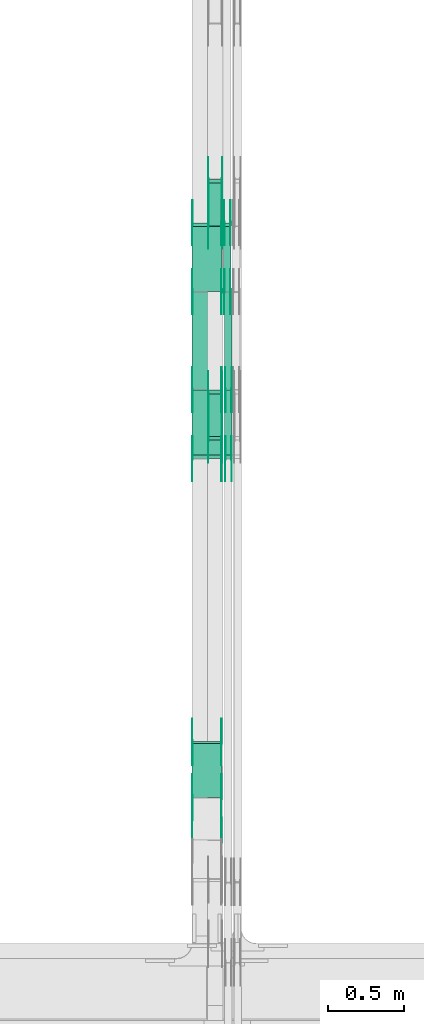
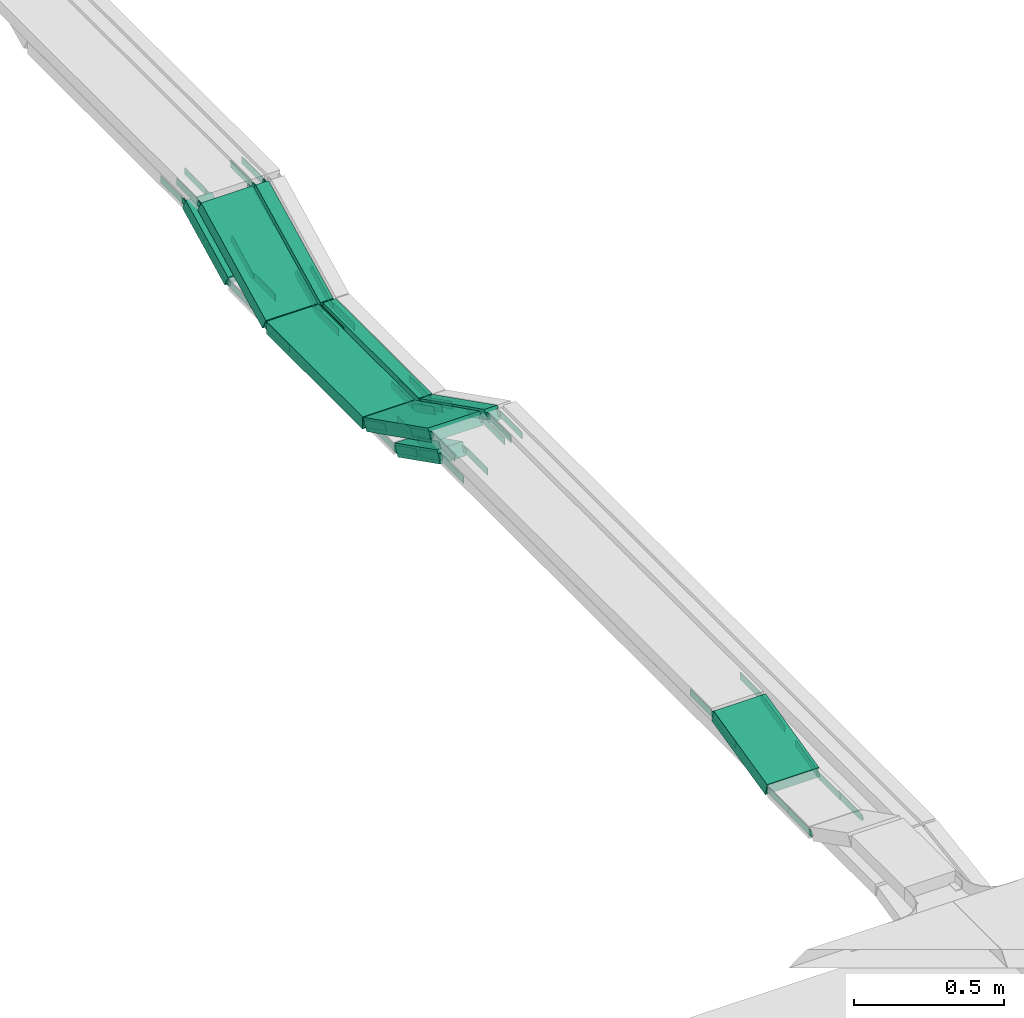
# One storey, part 18 of 27: 57 flow fittings, 9 flow segments.
"""IFC2X3 building model written with IfcOpenShell, lengths in millimetres."""

from ifc_helpers import new_model, entity, si_unit, converted_unit, derived_unit, direction, frame, frame_2d, origin, origin_2d_with_axis, place, context, subcontext, project, spatial, polyline, circle_curve, parameter, trimmed, segment, composite_curve, rectangle, outline, extrude, source, transform, mapped, material, type_object, type_shapes, element, save


model = new_model("IFC2X3")

# Units and contexts
model_context = context("Model", 3, precision=0.01, world=origin(), true_north=direction((6.12303176911189e-17, 1.0)))
body_context = subcontext(model_context, "Body", "Model", "MODEL_VIEW")
ifc_project = project(units=[si_unit("LENGTHUNIT", "METRE", prefix="MILLI"), si_unit("AREAUNIT", "SQUARE_METRE"), si_unit("VOLUMEUNIT", "CUBIC_METRE"), converted_unit("PLANEANGLEUNIT", "DEGREE", entity("IfcRatioMeasure", 0.0174532925199433), si_unit("PLANEANGLEUNIT", "RADIAN"), dimensions=[0, 0, 0, 0, 0, 0, 0]), si_unit("MASSUNIT", "GRAM", prefix="KILO"), derived_unit("MASSDENSITYUNIT", [(si_unit("MASSUNIT", "GRAM", prefix="KILO"), 1), (si_unit("LENGTHUNIT", "METRE"), -3)]), derived_unit("MOMENTOFINERTIAUNIT", [(si_unit("LENGTHUNIT", "METRE"), 4)]), si_unit("TIMEUNIT", "SECOND"), si_unit("FREQUENCYUNIT", "HERTZ"), si_unit("THERMODYNAMICTEMPERATUREUNIT", "DEGREE_CELSIUS"), derived_unit("THERMALTRANSMITTANCEUNIT", [(si_unit("MASSUNIT", "GRAM", prefix="KILO"), 1), (si_unit("THERMODYNAMICTEMPERATUREUNIT", "KELVIN"), -1), (si_unit("TIMEUNIT", "SECOND"), -3)]), derived_unit("VOLUMETRICFLOWRATEUNIT", [(si_unit("LENGTHUNIT", "METRE"), 3), (si_unit("TIMEUNIT", "SECOND"), -1)]), derived_unit("MASSFLOWRATEUNIT", [(si_unit("MASSUNIT", "GRAM", prefix="KILO"), 1), (si_unit("TIMEUNIT", "SECOND"), -1)]), derived_unit("ROTATIONALFREQUENCYUNIT", [(si_unit("TIMEUNIT", "SECOND"), -1)]), si_unit("ELECTRICCURRENTUNIT", "AMPERE"), si_unit("ELECTRICVOLTAGEUNIT", "VOLT"), si_unit("POWERUNIT", "WATT"), si_unit("FORCEUNIT", "NEWTON", prefix="KILO"), si_unit("ILLUMINANCEUNIT", "LUX"), si_unit("LUMINOUSFLUXUNIT", "LUMEN"), si_unit("LUMINOUSINTENSITYUNIT", "CANDELA"), derived_unit("USERDEFINED", [(si_unit("MASSUNIT", "GRAM", prefix="KILO"), -1), (si_unit("LENGTHUNIT", "METRE"), -2), (si_unit("TIMEUNIT", "SECOND"), 3), (si_unit("LUMINOUSFLUXUNIT", "LUMEN"), 1)]), derived_unit("LINEARVELOCITYUNIT", [(si_unit("LENGTHUNIT", "METRE"), 1), (si_unit("TIMEUNIT", "SECOND"), -1)]), si_unit("PRESSUREUNIT", "PASCAL"), derived_unit("USERDEFINED", [(si_unit("LENGTHUNIT", "METRE"), -2), (si_unit("MASSUNIT", "GRAM", prefix="KILO"), 1), (si_unit("TIMEUNIT", "SECOND"), -2)]), derived_unit("LINEARFORCEUNIT", [(si_unit("MASSUNIT", "GRAM", prefix="KILO"), 1), (si_unit("LENGTHUNIT", "METRE"), 1), (si_unit("TIMEUNIT", "SECOND"), -2), (si_unit("LENGTHUNIT", "METRE"), -1)]), derived_unit("PLANARFORCEUNIT", [(si_unit("MASSUNIT", "GRAM", prefix="KILO"), 1), (si_unit("LENGTHUNIT", "METRE"), 1), (si_unit("TIMEUNIT", "SECOND"), -2), (si_unit("LENGTHUNIT", "METRE"), -2)])], contexts=[model_context])

# Site, building, storey
site_placement = place(None, origin())
site = spatial("IfcSite", under=ifc_project, at=site_placement, CompositionType="ELEMENT")
building_placement = place(site_placement, origin())
building = spatial("IfcBuilding", under=site, at=building_placement, CompositionType="ELEMENT")
storey_placement = place(building_placement, origin())
storey = spatial("IfcBuildingStorey", under=building, at=storey_placement, CompositionType="ELEMENT", Elevation=0.0)

# Flow segments
cable_carrier_segment_type = type_object("IfcCableCarrierSegmentType", PredefinedType="CABLETRAYSEGMENT")
flow_segment_1_placement = place(storey_placement, frame((46847.77, 13767.29, 2456.23)))
element("IfcFlowSegment", 1, at=flow_segment_1_placement, inside=storey, type_object=cable_carrier_segment_type, context=body_context, shape_type="SweptSolid", body=[
    extrude(rectangle(XDim=50.0000000000002, YDim=317.472558766538, at=frame_2d((0.0, 0.0), x_axis=(0.0, 1.0))), frame((0.0, 153.0, 93.77), z_axis=(1.0, 0.0, 0.0), x_axis=(0.0, -0.892980854207483, -0.450094650066931)), (0.0, 0.0, 1.0), 99.9999999999946),
])
flow_segment_2_placement = place(storey_placement, frame((46847.77, 12350.31, 2456.23)))
element("IfcFlowSegment", 2, at=flow_segment_2_placement, inside=storey, type_object=cable_carrier_segment_type, context=body_context, shape_type="SweptSolid", body=[
    extrude(rectangle(XDim=50.0000000000016, YDim=317.472558766714, at=frame_2d((0.0, 0.0), x_axis=(0.0, 1.0))), frame((0.0, 153.0, 93.77), z_axis=(1.0, 0.0, 0.0), x_axis=(0.0, 0.89298085420761, -0.45009465006668)), (0.0, 0.0, 1.0), 99.9999999999946),
])
flow_segment_3_placement = place(storey_placement, frame((46959.82, 12227.8, 2581.18)))
element("IfcFlowSegment", 3, at=flow_segment_3_placement, inside=storey, type_object=cable_carrier_segment_type, context=body_context, shape_type="SweptSolid", body=[
    extrude(rectangle(XDim=49.9999999999997, YDim=484.209321850172, at=frame_2d((0.0, 0.0), x_axis=(0.0, 1.0))), frame((0.0, 227.45, 131.29), z_axis=(1.0, 0.0, 0.0), x_axis=(0.0, 0.892980854208928, -0.450094650064066)), (0.0, 0.0, 1.0), 50.000000000006),
])
flow_segment_4_placement = place(storey_placement, frame((46959.82, 12686.39, 2574.95)))
element("IfcFlowSegment", 4, at=flow_segment_4_placement, inside=storey, type_object=cable_carrier_segment_type, context=body_context, shape_type="SweptSolid", body=[
    extrude(rectangle(XDim=642.104660924055, YDim=50.000000000006, at=origin_2d_with_axis()), frame((25.0, 321.05, 0.0), z_axis=(0.0, 0.0, 1.0), x_axis=(0.0, 1.0, 0.0)), (0.0, 0.0, 1.0), 49.9999999999995),
])
flow_segment_5_placement = place(storey_placement, frame((46952.18, 13332.18, 2581.18)))
element("IfcFlowSegment", 5, at=flow_segment_5_placement, inside=storey, type_object=cable_carrier_segment_type, context=body_context, shape_type="SweptSolid", body=[
    extrude(rectangle(XDim=50.000000000001, YDim=484.209321850269, at=frame_2d((0.0, 0.0), x_axis=(0.0, 1.0))), frame((0.0, 227.45, 131.29), z_axis=(1.0, 0.0, 0.0), x_axis=(0.0, -0.892980854206691, -0.450094650068503)), (0.0, 0.0, 1.0), 50.000000000006),
])
flow_segment_6_placement = place(storey_placement, frame((46742.18, 12227.8, 2581.18)))
element("IfcFlowSegment", 6, at=flow_segment_6_placement, inside=storey, type_object=cable_carrier_segment_type, context=body_context, shape_type="SweptSolid", body=[
    extrude(rectangle(XDim=50.0000000000007, YDim=484.209321849835, at=frame_2d((0.0, 0.0), x_axis=(0.0, 1.0))), frame((0.0, 227.45, 131.29), z_axis=(1.0, 0.0, 0.0), x_axis=(0.0, 0.892980854208896, -0.450094650064129)), (0.0, 0.0, 1.0), 200.000000000007),
])
flow_segment_7_placement = place(storey_placement, frame((46742.18, 12686.39, 2574.95)))
element("IfcFlowSegment", 7, at=flow_segment_7_placement, inside=storey, type_object=cable_carrier_segment_type, context=body_context, shape_type="SweptSolid", body=[
    extrude(rectangle(XDim=642.104660927451, YDim=200.000000000007, at=origin_2d_with_axis()), frame((100.0, 321.05, 0.0), z_axis=(0.0, 0.0, 1.0), x_axis=(0.0, 1.0, 0.0)), (0.0, 0.0, 1.0), 50.0000000000005),
])
flow_segment_8_placement = place(storey_placement, frame((46742.18, 13332.18, 2581.18)))
element("IfcFlowSegment", 8, at=flow_segment_8_placement, inside=storey, type_object=cable_carrier_segment_type, context=body_context, shape_type="SweptSolid", body=[
    extrude(rectangle(XDim=50.0000000000005, YDim=484.209321846522, at=frame_2d((0.0, 0.0), x_axis=(0.0, 1.0))), frame((0.0, 227.45, 131.29), z_axis=(1.0, 0.0, 0.0), x_axis=(0.0, -0.892980854206786, -0.450094650068315)), (0.0, 0.0, 1.0), 200.000000000007),
])
flow_segment_9_placement = place(storey_placement, frame((46742.18, 9985.82, 2715.48)))
element("IfcFlowSegment", 9, at=flow_segment_9_placement, inside=storey, type_object=cable_carrier_segment_type, context=body_context, shape_type="SweptSolid", body=[
    extrude(rectangle(XDim=49.9999999999991, YDim=366.558489644676, at=frame_2d((0.0, 0.0), x_axis=(0.0, 1.0))), frame((0.0, 184.12, 66.43), z_axis=(1.0, 0.0, 0.0), x_axis=(0.0, 0.973268623518919, 0.229669733473065)), (0.0, 0.0, 1.0), 200.000000000007),
])

# Flow fittings
ifc_material = material(Name="G")
cable_carrier_fitting_type_1 = type_object("IfcCableCarrierFittingType", PredefinedType="NOTDEFINED", material=ifc_material)
shared_shape_1 = source(origin(), body_context, "Body", "SweptSolid", [
    extrude(outline(composite_curve([segment(trimmed(circle_curve(frame_2d((-44.59, 0.0), x_axis=(1.0, 0.0)), 12.5), [parameter(90.0000000000007)], [parameter(270.0)], True, "PARAMETER"), True, "CONTINUOUS"), segment(polyline([(-44.59, -12.5), (-33.09, -12.5)]), True, "CONTINUOUS"), segment(polyline([(-33.09, -12.5), (-31.23, -14.5)]), True, "CONTINUOUS"), segment(polyline([(-31.23, -14.5), (108.91, -14.5)]), True, "CONTINUOUS"), segment(polyline([(108.91, -14.5), (108.91, 14.5)]), True, "CONTINUOUS"), segment(polyline([(108.91, 14.5), (-31.23, 14.5)]), True, "CONTINUOUS"), segment(polyline([(-31.23, 14.5), (-33.09, 12.5)]), True, "CONTINUOUS"), segment(polyline([(-33.09, 12.5), (-44.59, 12.5)]), True, "CONTINUOUS")], self_intersect=False)), frame((44.59, 0.0, 0.0), z_axis=(0.0, 0.0, -1.0), x_axis=(1.0, 0.0, 0.0)), (0.0, 0.0, -1.0), 2.0),
])
type_shapes(cable_carrier_fitting_type_1, [shared_shape_1])
flow_fitting_1_placement = place(storey_placement, frame((46852.31, 13771.5, 2475.0), z_axis=(-1.0, 0.0, 0.0), x_axis=(0.0, -1.0, 0.0)))
element("IfcFlowFitting", 10, at=flow_fitting_1_placement, inside=storey, type_object=cable_carrier_fitting_type_1, material=ifc_material, context=body_context, shape_type="MappedRepresentation", body=[
    mapped(shared_shape_1, transform((0.0, 0.0, 0.0), scale=1.0)),
])
cable_carrier_fitting_type_2 = type_object("IfcCableCarrierFittingType", PredefinedType="NOTDEFINED", material=ifc_material)
type_shapes(cable_carrier_fitting_type_2, [shared_shape_1])
flow_fitting_2_placement = place(storey_placement, frame((46941.23, 13771.5, 2475.0), z_axis=(1.0, 0.0, 0.0), x_axis=(0.0, 0.892980854206722, 0.450094650068442)))
element("IfcFlowFitting", 11, at=flow_fitting_2_placement, inside=storey, type_object=cable_carrier_fitting_type_2, material=ifc_material, context=body_context, shape_type="MappedRepresentation", body=[
    mapped(shared_shape_1, transform((0.0, 0.0, 0.0), scale=1.0)),
])
flow_fitting_3_placement = place(storey_placement, frame((46943.23, 12652.1, 2475.0), z_axis=(1.0, 0.0, 0.0), x_axis=(0.0, 1.0, 0.0)))
element("IfcFlowFitting", 12, at=flow_fitting_3_placement, inside=storey, type_object=cable_carrier_fitting_type_1, material=ifc_material, context=body_context, shape_type="MappedRepresentation", body=[
    mapped(shared_shape_1, transform((0.0, 0.0, 0.0), scale=1.0)),
])
flow_fitting_4_placement = place(storey_placement, frame((46854.31, 12652.1, 2475.0), z_axis=(-1.0, 0.0, 0.0), x_axis=(0.0, -0.892980854206722, 0.450094650068442)))
element("IfcFlowFitting", 13, at=flow_fitting_4_placement, inside=storey, type_object=cable_carrier_fitting_type_2, material=ifc_material, context=body_context, shape_type="MappedRepresentation", body=[
    mapped(shared_shape_1, transform((0.0, 0.0, 0.0), scale=1.0)),
])
flow_fitting_5_placement = place(storey_placement, frame((46943.23, 12354.51, 2625.0), z_axis=(1.0, 0.0, 0.0), x_axis=(0.0, -1.0, 0.0)))
element("IfcFlowFitting", 14, at=flow_fitting_5_placement, inside=storey, type_object=cable_carrier_fitting_type_1, material=ifc_material, context=body_context, shape_type="MappedRepresentation", body=[
    mapped(shared_shape_1, transform((0.0, 0.0, 0.0), scale=1.0)),
])
flow_fitting_6_placement = place(storey_placement, frame((46854.31, 12354.51, 2625.0), z_axis=(-1.0, 0.0, 0.0), x_axis=(0.0, 0.892980854206848, -0.450094650068192)))
element("IfcFlowFitting", 15, at=flow_fitting_6_placement, inside=storey, type_object=cable_carrier_fitting_type_2, material=ifc_material, context=body_context, shape_type="MappedRepresentation", body=[
    mapped(shared_shape_1, transform((0.0, 0.0, 0.0), scale=1.0)),
])
flow_fitting_7_placement = place(storey_placement, frame((47005.28, 12678.49, 2599.95), z_axis=(1.0, 0.0, 0.0), x_axis=(0.0, 1.0, 0.0)))
element("IfcFlowFitting", 16, at=flow_fitting_7_placement, inside=storey, type_object=cable_carrier_fitting_type_1, material=ifc_material, context=body_context, shape_type="MappedRepresentation", body=[
    mapped(shared_shape_1, transform((0.0, 0.0, 0.0), scale=1.0)),
])
flow_fitting_8_placement = place(storey_placement, frame((46966.36, 12678.49, 2599.95), z_axis=(-1.0, 0.0, 0.0), x_axis=(0.0, -0.892980854206714, 0.450094650068457)))
element("IfcFlowFitting", 17, at=flow_fitting_8_placement, inside=storey, type_object=cable_carrier_fitting_type_2, material=ifc_material, context=body_context, shape_type="MappedRepresentation", body=[
    mapped(shared_shape_1, transform((0.0, 0.0, 0.0), scale=1.0)),
])
cable_carrier_fitting_type_3 = type_object("IfcCableCarrierFittingType", PredefinedType="NOTDEFINED", material=ifc_material)
type_shapes(cable_carrier_fitting_type_3, [shared_shape_1])
flow_fitting_9_placement = place(storey_placement, frame((46956.72, 13336.39, 2599.95), z_axis=(-1.0, 0.0, 0.0), x_axis=(0.0, -1.0, 0.0)))
element("IfcFlowFitting", 18, at=flow_fitting_9_placement, inside=storey, type_object=cable_carrier_fitting_type_3, material=ifc_material, context=body_context, shape_type="MappedRepresentation", body=[
    mapped(shared_shape_1, transform((0.0, 0.0, 0.0), scale=1.0)),
])
flow_fitting_10_placement = place(storey_placement, frame((46995.64, 13336.39, 2599.95), z_axis=(1.0, 0.0, 0.0), x_axis=(0.0, 0.892980854206714, 0.450094650068457)))
element("IfcFlowFitting", 19, at=flow_fitting_10_placement, inside=storey, type_object=cable_carrier_fitting_type_2, material=ifc_material, context=body_context, shape_type="MappedRepresentation", body=[
    mapped(shared_shape_1, transform((0.0, 0.0, 0.0), scale=1.0)),
])
flow_fitting_11_placement = place(storey_placement, frame((46956.72, 13782.88, 2825.0), z_axis=(-1.0, 0.0, 0.0), x_axis=(0.0, 1.0, 0.0)))
element("IfcFlowFitting", 20, at=flow_fitting_11_placement, inside=storey, type_object=cable_carrier_fitting_type_1, material=ifc_material, context=body_context, shape_type="MappedRepresentation", body=[
    mapped(shared_shape_1, transform((0.0, 0.0, 0.0), scale=1.0)),
])
flow_fitting_12_placement = place(storey_placement, frame((46995.64, 13782.88, 2825.0), z_axis=(1.0, 0.0, 0.0), x_axis=(0.0, -0.892980854206701, -0.450094650068483)))
element("IfcFlowFitting", 21, at=flow_fitting_12_placement, inside=storey, type_object=cable_carrier_fitting_type_2, material=ifc_material, context=body_context, shape_type="MappedRepresentation", body=[
    mapped(shared_shape_1, transform((0.0, 0.0, 0.0), scale=1.0)),
])
flow_fitting_13_placement = place(storey_placement, frame((47005.28, 12232.0, 2825.0), z_axis=(1.0, 0.0, 0.0), x_axis=(0.0, -1.0, 0.0)))
element("IfcFlowFitting", 22, at=flow_fitting_13_placement, inside=storey, type_object=cable_carrier_fitting_type_1, material=ifc_material, context=body_context, shape_type="MappedRepresentation", body=[
    mapped(shared_shape_1, transform((0.0, 0.0, 0.0), scale=1.0)),
])
flow_fitting_14_placement = place(storey_placement, frame((46966.36, 12232.0, 2825.0), z_axis=(-1.0, 0.0, 0.0), x_axis=(0.0, 0.892980854206734, -0.450094650068419)))
element("IfcFlowFitting", 23, at=flow_fitting_14_placement, inside=storey, type_object=cable_carrier_fitting_type_2, material=ifc_material, context=body_context, shape_type="MappedRepresentation", body=[
    mapped(shared_shape_1, transform((0.0, 0.0, 0.0), scale=1.0)),
])
for number, where, z_axis, x_axis in (
    (24, (46937.64, 9697.3, 2738.8), (1.0, 0.0, 0.0), (0.0, 1.0, 0.0)),
    (25, (46937.64, 9987.3, 2738.8), (1.0, 0.0, 0.0), (0.0, 0.97326862351892, 0.229669733473063)),
):
    element("IfcFlowFitting", number, at=place(storey_placement, frame(where, z_axis=z_axis, x_axis=x_axis)), inside=storey, type_object=cable_carrier_fitting_type_1, material=ifc_material, context=body_context, shape_type="MappedRepresentation", body=[
        mapped(shared_shape_1, transform((0.0, 0.0, 0.0), scale=1.0)),
    ])
flow_fitting_15_placement = place(storey_placement, frame((46748.72, 9987.3, 2738.8), z_axis=(-1.0, 0.0, 0.0), x_axis=(0.0, -1.0, 0.0)))
element("IfcFlowFitting", 26, at=flow_fitting_15_placement, inside=storey, type_object=cable_carrier_fitting_type_2, material=ifc_material, context=body_context, shape_type="MappedRepresentation", body=[
    mapped(shared_shape_1, transform((0.0, 0.0, 0.0), scale=1.0)),
])
flow_fitting_16_placement = place(storey_placement, frame((46937.64, 12232.0, 2825.0), z_axis=(1.0, 0.0, 0.0), x_axis=(0.0, -1.0, 0.0)))
element("IfcFlowFitting", 27, at=flow_fitting_16_placement, inside=storey, type_object=cable_carrier_fitting_type_1, material=ifc_material, context=body_context, shape_type="MappedRepresentation", body=[
    mapped(shared_shape_1, transform((0.0, 0.0, 0.0), scale=1.0)),
])
flow_fitting_17_placement = place(storey_placement, frame((46748.72, 12232.0, 2825.0), z_axis=(-1.0, 0.0, 0.0), x_axis=(0.0, 0.892980854206683, -0.45009465006852)))
element("IfcFlowFitting", 28, at=flow_fitting_17_placement, inside=storey, type_object=cable_carrier_fitting_type_2, material=ifc_material, context=body_context, shape_type="MappedRepresentation", body=[
    mapped(shared_shape_1, transform((0.0, 0.0, 0.0), scale=1.0)),
])
flow_fitting_18_placement = place(storey_placement, frame((46746.72, 10352.58, 2825.0), z_axis=(-1.0, 0.0, 0.0), x_axis=(0.0, 1.0, 0.0)))
element("IfcFlowFitting", 29, at=flow_fitting_18_placement, inside=storey, type_object=cable_carrier_fitting_type_1, material=ifc_material, context=body_context, shape_type="MappedRepresentation", body=[
    mapped(shared_shape_1, transform((0.0, 0.0, 0.0), scale=1.0)),
])
flow_fitting_19_placement = place(storey_placement, frame((46935.64, 10352.58, 2825.0), z_axis=(1.0, 0.0, 0.0), x_axis=(0.0, -0.973268623518927, -0.229669733473034)))
element("IfcFlowFitting", 30, at=flow_fitting_19_placement, inside=storey, type_object=cable_carrier_fitting_type_2, material=ifc_material, context=body_context, shape_type="MappedRepresentation", body=[
    mapped(shared_shape_1, transform((0.0, 0.0, 0.0), scale=1.0)),
])
flow_fitting_20_placement = place(storey_placement, frame((46852.31, 14069.09, 2625.0), z_axis=(-1.0, 0.0, 0.0), x_axis=(0.0, 1.0, 0.0)))
element("IfcFlowFitting", 31, at=flow_fitting_20_placement, inside=storey, type_object=cable_carrier_fitting_type_1, material=ifc_material, context=body_context, shape_type="MappedRepresentation", body=[
    mapped(shared_shape_1, transform((0.0, 0.0, 0.0), scale=1.0)),
])
flow_fitting_21_placement = place(storey_placement, frame((46941.23, 14069.09, 2625.0), z_axis=(1.0, 0.0, 0.0), x_axis=(0.0, -0.892980854207486, -0.450094650066926)))
element("IfcFlowFitting", 32, at=flow_fitting_21_placement, inside=storey, type_object=cable_carrier_fitting_type_2, material=ifc_material, context=body_context, shape_type="MappedRepresentation", body=[
    mapped(shared_shape_1, transform((0.0, 0.0, 0.0), scale=1.0)),
])
flow_fitting_22_placement = place(storey_placement, frame((46937.64, 12678.49, 2599.95), z_axis=(1.0, 0.0, 0.0), x_axis=(0.0, 1.0, 0.0)))
element("IfcFlowFitting", 33, at=flow_fitting_22_placement, inside=storey, type_object=cable_carrier_fitting_type_1, material=ifc_material, context=body_context, shape_type="MappedRepresentation", body=[
    mapped(shared_shape_1, transform((0.0, 0.0, 0.0), scale=1.0)),
])
flow_fitting_23_placement = place(storey_placement, frame((46748.72, 12678.49, 2599.95), z_axis=(-1.0, 0.0, 0.0), x_axis=(0.0, -0.892980854208899, 0.450094650064124)))
element("IfcFlowFitting", 34, at=flow_fitting_23_placement, inside=storey, type_object=cable_carrier_fitting_type_2, material=ifc_material, context=body_context, shape_type="MappedRepresentation", body=[
    mapped(shared_shape_1, transform((0.0, 0.0, 0.0), scale=1.0)),
])
flow_fitting_24_placement = place(storey_placement, frame((46937.64, 13782.88, 2825.0), z_axis=(1.0, 0.0, 0.0), x_axis=(0.0, -0.892980854206745, -0.450094650068397)))
element("IfcFlowFitting", 35, at=flow_fitting_24_placement, inside=storey, type_object=cable_carrier_fitting_type_1, material=ifc_material, context=body_context, shape_type="MappedRepresentation", body=[
    mapped(shared_shape_1, transform((0.0, 0.0, 0.0), scale=1.0)),
])
flow_fitting_25_placement = place(storey_placement, frame((46748.72, 13782.88, 2825.0), z_axis=(-1.0, 0.0, 0.0), x_axis=(0.0, 1.0, 0.0)))
element("IfcFlowFitting", 36, at=flow_fitting_25_placement, inside=storey, type_object=cable_carrier_fitting_type_2, material=ifc_material, context=body_context, shape_type="MappedRepresentation", body=[
    mapped(shared_shape_1, transform((0.0, 0.0, 0.0), scale=1.0)),
])
flow_fitting_26_placement = place(storey_placement, frame((46937.64, 13336.39, 2599.95), z_axis=(1.0, 0.0, 0.0), x_axis=(0.0, 0.892980854206745, 0.450094650068397)))
element("IfcFlowFitting", 37, at=flow_fitting_26_placement, inside=storey, type_object=cable_carrier_fitting_type_1, material=ifc_material, context=body_context, shape_type="MappedRepresentation", body=[
    mapped(shared_shape_1, transform((0.0, 0.0, 0.0), scale=1.0)),
])
flow_fitting_27_placement = place(storey_placement, frame((46748.72, 13336.39, 2599.95), z_axis=(-1.0, 0.0, 0.0), x_axis=(0.0, -1.0, 0.0)))
element("IfcFlowFitting", 38, at=flow_fitting_27_placement, inside=storey, type_object=cable_carrier_fitting_type_2, material=ifc_material, context=body_context, shape_type="MappedRepresentation", body=[
    mapped(shared_shape_1, transform((0.0, 0.0, 0.0), scale=1.0)),
])
cable_carrier_fitting_type_4 = type_object("IfcCableCarrierFittingType", PredefinedType="NOTDEFINED", material=ifc_material)
shared_shape_2 = source(origin(), body_context, "Body", "SweptSolid", [
    extrude(outline(composite_curve([segment(trimmed(circle_curve(frame_2d((-44.59, 0.0), x_axis=(1.0, 0.0)), 12.5), [parameter(90.0000000000007)], [parameter(270.0)], True, "PARAMETER"), True, "CONTINUOUS"), segment(polyline([(-44.59, -12.5), (-33.09, -12.5)]), True, "CONTINUOUS"), segment(polyline([(-33.09, -12.5), (-31.23, -14.5)]), True, "CONTINUOUS"), segment(polyline([(-31.23, -14.5), (108.91, -14.5)]), True, "CONTINUOUS"), segment(polyline([(108.91, -14.5), (108.91, 14.5)]), True, "CONTINUOUS"), segment(polyline([(108.91, 14.5), (-31.23, 14.5)]), True, "CONTINUOUS"), segment(polyline([(-31.23, 14.5), (-33.09, 12.5)]), True, "CONTINUOUS"), segment(polyline([(-33.09, 12.5), (-44.59, 12.5)]), True, "CONTINUOUS")], self_intersect=False)), frame((44.59, 0.0, 0.0)), (0.0, 0.0, 1.0), 2.0),
])
type_shapes(cable_carrier_fitting_type_4, [shared_shape_2])
flow_fitting_28_placement = place(storey_placement, frame((46943.23, 13771.5, 2475.0), z_axis=(1.0, 0.0, 0.0), x_axis=(0.0, -1.0, 0.0)))
element("IfcFlowFitting", 39, at=flow_fitting_28_placement, inside=storey, type_object=cable_carrier_fitting_type_4, material=ifc_material, context=body_context, shape_type="MappedRepresentation", body=[
    mapped(shared_shape_2, transform((0.0, 0.0, 0.0), scale=1.0)),
])
cable_carrier_fitting_type_5 = type_object("IfcCableCarrierFittingType", PredefinedType="NOTDEFINED", material=ifc_material)
type_shapes(cable_carrier_fitting_type_5, [shared_shape_2])
flow_fitting_29_placement = place(storey_placement, frame((46854.31, 13771.5, 2475.0), z_axis=(-1.0, 0.0, 0.0), x_axis=(0.0, 0.892980854206722, 0.450094650068442)))
element("IfcFlowFitting", 40, at=flow_fitting_29_placement, inside=storey, type_object=cable_carrier_fitting_type_5, material=ifc_material, context=body_context, shape_type="MappedRepresentation", body=[
    mapped(shared_shape_2, transform((0.0, 0.0, 0.0), scale=1.0)),
])
flow_fitting_30_placement = place(storey_placement, frame((46852.31, 12652.1, 2475.0), z_axis=(-1.0, 0.0, 0.0), x_axis=(0.0, 1.0, 0.0)))
element("IfcFlowFitting", 41, at=flow_fitting_30_placement, inside=storey, type_object=cable_carrier_fitting_type_4, material=ifc_material, context=body_context, shape_type="MappedRepresentation", body=[
    mapped(shared_shape_2, transform((0.0, 0.0, 0.0), scale=1.0)),
])
flow_fitting_31_placement = place(storey_placement, frame((46941.23, 12652.1, 2475.0), z_axis=(1.0, 0.0, 0.0), x_axis=(0.0, -0.892980854206722, 0.450094650068442)))
element("IfcFlowFitting", 42, at=flow_fitting_31_placement, inside=storey, type_object=cable_carrier_fitting_type_5, material=ifc_material, context=body_context, shape_type="MappedRepresentation", body=[
    mapped(shared_shape_2, transform((0.0, 0.0, 0.0), scale=1.0)),
])
flow_fitting_32_placement = place(storey_placement, frame((46852.31, 12354.51, 2625.0), z_axis=(-1.0, 0.0, 0.0), x_axis=(0.0, -1.0, 0.0)))
element("IfcFlowFitting", 43, at=flow_fitting_32_placement, inside=storey, type_object=cable_carrier_fitting_type_4, material=ifc_material, context=body_context, shape_type="MappedRepresentation", body=[
    mapped(shared_shape_2, transform((0.0, 0.0, 0.0), scale=1.0)),
])
flow_fitting_33_placement = place(storey_placement, frame((46941.23, 12354.51, 2625.0), z_axis=(1.0, 0.0, 0.0), x_axis=(0.0, 0.892980854206848, -0.450094650068192)))
element("IfcFlowFitting", 44, at=flow_fitting_33_placement, inside=storey, type_object=cable_carrier_fitting_type_5, material=ifc_material, context=body_context, shape_type="MappedRepresentation", body=[
    mapped(shared_shape_2, transform((0.0, 0.0, 0.0), scale=1.0)),
])
flow_fitting_34_placement = place(storey_placement, frame((46964.36, 12678.49, 2599.95), z_axis=(-1.0, 0.0, 0.0), x_axis=(0.0, 1.0, 0.0)))
element("IfcFlowFitting", 45, at=flow_fitting_34_placement, inside=storey, type_object=cable_carrier_fitting_type_4, material=ifc_material, context=body_context, shape_type="MappedRepresentation", body=[
    mapped(shared_shape_2, transform((0.0, 0.0, 0.0), scale=1.0)),
])
flow_fitting_35_placement = place(storey_placement, frame((47003.28, 12678.49, 2599.95), z_axis=(1.0, 0.0, 0.0), x_axis=(0.0, -0.892980854206714, 0.450094650068457)))
element("IfcFlowFitting", 46, at=flow_fitting_35_placement, inside=storey, type_object=cable_carrier_fitting_type_5, material=ifc_material, context=body_context, shape_type="MappedRepresentation", body=[
    mapped(shared_shape_2, transform((0.0, 0.0, 0.0), scale=1.0)),
])
cable_carrier_fitting_type_6 = type_object("IfcCableCarrierFittingType", PredefinedType="NOTDEFINED", material=ifc_material)
type_shapes(cable_carrier_fitting_type_6, [shared_shape_2])
flow_fitting_36_placement = place(storey_placement, frame((46997.64, 13336.39, 2599.95), z_axis=(1.0, 0.0, 0.0), x_axis=(0.0, -1.0, 0.0)))
element("IfcFlowFitting", 47, at=flow_fitting_36_placement, inside=storey, type_object=cable_carrier_fitting_type_6, material=ifc_material, context=body_context, shape_type="MappedRepresentation", body=[
    mapped(shared_shape_2, transform((0.0, 0.0, 0.0), scale=1.0)),
])
flow_fitting_37_placement = place(storey_placement, frame((46958.72, 13336.39, 2599.95), z_axis=(-1.0, 0.0, 0.0), x_axis=(0.0, 0.892980854206714, 0.450094650068457)))
element("IfcFlowFitting", 48, at=flow_fitting_37_placement, inside=storey, type_object=cable_carrier_fitting_type_5, material=ifc_material, context=body_context, shape_type="MappedRepresentation", body=[
    mapped(shared_shape_2, transform((0.0, 0.0, 0.0), scale=1.0)),
])
flow_fitting_38_placement = place(storey_placement, frame((46997.64, 13782.88, 2825.0), z_axis=(1.0, 0.0, 0.0), x_axis=(0.0, 1.0, 0.0)))
element("IfcFlowFitting", 49, at=flow_fitting_38_placement, inside=storey, type_object=cable_carrier_fitting_type_4, material=ifc_material, context=body_context, shape_type="MappedRepresentation", body=[
    mapped(shared_shape_2, transform((0.0, 0.0, 0.0), scale=1.0)),
])
flow_fitting_39_placement = place(storey_placement, frame((46958.72, 13782.88, 2825.0), z_axis=(-1.0, 0.0, 0.0), x_axis=(0.0, -0.892980854206701, -0.450094650068483)))
element("IfcFlowFitting", 50, at=flow_fitting_39_placement, inside=storey, type_object=cable_carrier_fitting_type_5, material=ifc_material, context=body_context, shape_type="MappedRepresentation", body=[
    mapped(shared_shape_2, transform((0.0, 0.0, 0.0), scale=1.0)),
])
flow_fitting_40_placement = place(storey_placement, frame((46964.36, 12232.0, 2825.0), z_axis=(-1.0, 0.0, 0.0), x_axis=(0.0, -1.0, 0.0)))
element("IfcFlowFitting", 51, at=flow_fitting_40_placement, inside=storey, type_object=cable_carrier_fitting_type_4, material=ifc_material, context=body_context, shape_type="MappedRepresentation", body=[
    mapped(shared_shape_2, transform((0.0, 0.0, 0.0), scale=1.0)),
])
flow_fitting_41_placement = place(storey_placement, frame((47003.28, 12232.0, 2825.0), z_axis=(1.0, 0.0, 0.0), x_axis=(0.0, 0.892980854206734, -0.450094650068419)))
element("IfcFlowFitting", 52, at=flow_fitting_41_placement, inside=storey, type_object=cable_carrier_fitting_type_5, material=ifc_material, context=body_context, shape_type="MappedRepresentation", body=[
    mapped(shared_shape_2, transform((0.0, 0.0, 0.0), scale=1.0)),
])
for number, where, z_axis, x_axis in (
    (53, (46746.72, 9697.3, 2738.8), (-1.0, 0.0, 0.0), (0.0, 1.0, 0.0)),
    (54, (46746.72, 9987.3, 2738.8), (-1.0, 0.0, 0.0), (0.0, 0.97326862351892, 0.229669733473063)),
):
    element("IfcFlowFitting", number, at=place(storey_placement, frame(where, z_axis=z_axis, x_axis=x_axis)), inside=storey, type_object=cable_carrier_fitting_type_4, material=ifc_material, context=body_context, shape_type="MappedRepresentation", body=[
        mapped(shared_shape_2, transform((0.0, 0.0, 0.0), scale=1.0)),
    ])
flow_fitting_42_placement = place(storey_placement, frame((46935.64, 9987.3, 2738.8), z_axis=(1.0, 0.0, 0.0), x_axis=(0.0, -1.0, 0.0)))
element("IfcFlowFitting", 55, at=flow_fitting_42_placement, inside=storey, type_object=cable_carrier_fitting_type_5, material=ifc_material, context=body_context, shape_type="MappedRepresentation", body=[
    mapped(shared_shape_2, transform((0.0, 0.0, 0.0), scale=1.0)),
])
flow_fitting_43_placement = place(storey_placement, frame((46746.72, 12232.0, 2825.0), z_axis=(-1.0, 0.0, 0.0), x_axis=(0.0, -1.0, 0.0)))
element("IfcFlowFitting", 56, at=flow_fitting_43_placement, inside=storey, type_object=cable_carrier_fitting_type_4, material=ifc_material, context=body_context, shape_type="MappedRepresentation", body=[
    mapped(shared_shape_2, transform((0.0, 0.0, 0.0), scale=1.0)),
])
flow_fitting_44_placement = place(storey_placement, frame((46935.64, 12232.0, 2825.0), z_axis=(1.0, 0.0, 0.0), x_axis=(0.0, 0.892980854206683, -0.45009465006852)))
element("IfcFlowFitting", 57, at=flow_fitting_44_placement, inside=storey, type_object=cable_carrier_fitting_type_5, material=ifc_material, context=body_context, shape_type="MappedRepresentation", body=[
    mapped(shared_shape_2, transform((0.0, 0.0, 0.0), scale=1.0)),
])
flow_fitting_45_placement = place(storey_placement, frame((46937.64, 10352.58, 2825.0), z_axis=(1.0, 0.0, 0.0), x_axis=(0.0, 1.0, 0.0)))
element("IfcFlowFitting", 58, at=flow_fitting_45_placement, inside=storey, type_object=cable_carrier_fitting_type_4, material=ifc_material, context=body_context, shape_type="MappedRepresentation", body=[
    mapped(shared_shape_2, transform((0.0, 0.0, 0.0), scale=1.0)),
])
flow_fitting_46_placement = place(storey_placement, frame((46748.72, 10352.58, 2825.0), z_axis=(-1.0, 0.0, 0.0), x_axis=(0.0, -0.973268623518927, -0.229669733473034)))
element("IfcFlowFitting", 59, at=flow_fitting_46_placement, inside=storey, type_object=cable_carrier_fitting_type_5, material=ifc_material, context=body_context, shape_type="MappedRepresentation", body=[
    mapped(shared_shape_2, transform((0.0, 0.0, 0.0), scale=1.0)),
])
flow_fitting_47_placement = place(storey_placement, frame((46943.23, 14069.09, 2625.0), z_axis=(1.0, 0.0, 0.0), x_axis=(0.0, 1.0, 0.0)))
element("IfcFlowFitting", 60, at=flow_fitting_47_placement, inside=storey, type_object=cable_carrier_fitting_type_4, material=ifc_material, context=body_context, shape_type="MappedRepresentation", body=[
    mapped(shared_shape_2, transform((0.0, 0.0, 0.0), scale=1.0)),
])
flow_fitting_48_placement = place(storey_placement, frame((46854.31, 14069.09, 2625.0), z_axis=(-1.0, 0.0, 0.0), x_axis=(0.0, -0.892980854207486, -0.450094650066926)))
element("IfcFlowFitting", 61, at=flow_fitting_48_placement, inside=storey, type_object=cable_carrier_fitting_type_5, material=ifc_material, context=body_context, shape_type="MappedRepresentation", body=[
    mapped(shared_shape_2, transform((0.0, 0.0, 0.0), scale=1.0)),
])
flow_fitting_49_placement = place(storey_placement, frame((46746.72, 12678.49, 2599.95), z_axis=(-1.0, 0.0, 0.0), x_axis=(0.0, 1.0, 0.0)))
element("IfcFlowFitting", 62, at=flow_fitting_49_placement, inside=storey, type_object=cable_carrier_fitting_type_4, material=ifc_material, context=body_context, shape_type="MappedRepresentation", body=[
    mapped(shared_shape_2, transform((0.0, 0.0, 0.0), scale=1.0)),
])
flow_fitting_50_placement = place(storey_placement, frame((46935.64, 12678.49, 2599.95), z_axis=(1.0, 0.0, 0.0), x_axis=(0.0, -0.892980854208899, 0.450094650064124)))
element("IfcFlowFitting", 63, at=flow_fitting_50_placement, inside=storey, type_object=cable_carrier_fitting_type_5, material=ifc_material, context=body_context, shape_type="MappedRepresentation", body=[
    mapped(shared_shape_2, transform((0.0, 0.0, 0.0), scale=1.0)),
])
for number, where, z_axis, x_axis in (
    (64, (46746.72, 13782.88, 2825.0), (-1.0, 0.0, 0.0), (0.0, -0.892980854206745, -0.450094650068397)),
    (65, (46746.72, 13336.39, 2599.95), (-1.0, 0.0, 0.0), (0.0, 0.892980854206745, 0.450094650068397)),
):
    element("IfcFlowFitting", number, at=place(storey_placement, frame(where, z_axis=z_axis, x_axis=x_axis)), inside=storey, type_object=cable_carrier_fitting_type_4, material=ifc_material, context=body_context, shape_type="MappedRepresentation", body=[
        mapped(shared_shape_2, transform((0.0, 0.0, 0.0), scale=1.0)),
    ])
flow_fitting_51_placement = place(storey_placement, frame((46935.64, 13336.39, 2599.95), z_axis=(1.0, 0.0, 0.0), x_axis=(0.0, -1.0, 0.0)))
element("IfcFlowFitting", 66, at=flow_fitting_51_placement, inside=storey, type_object=cable_carrier_fitting_type_5, material=ifc_material, context=body_context, shape_type="MappedRepresentation", body=[
    mapped(shared_shape_2, transform((0.0, 0.0, 0.0), scale=1.0)),
])

save(model, "model.ifc")
